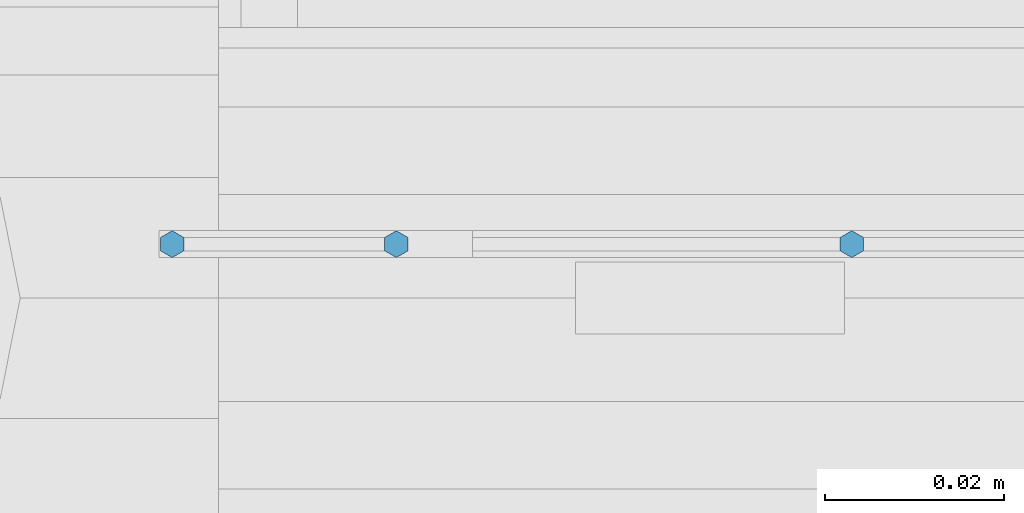
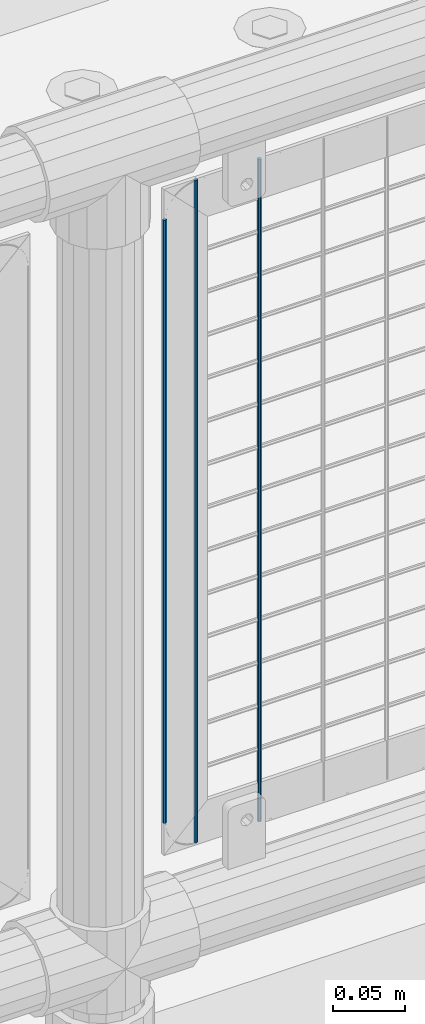
# One storey, part 103 of 242: 3 columns.
"""IFC2X3 building model written with IfcOpenShell, lengths in millimetres."""

from ifc_helpers import new_model, si_unit, frame, origin_with_axes, place, context, subcontext, project, spatial, faceted_brep, material, type_object, element, save


model = new_model("IFC2X3")

# Units and contexts
model_context = context("Model", 3, precision=1e-05, world=origin_with_axes())
body_context = subcontext(model_context, "Body", "Model", "MODEL_VIEW")
ifc_project = project(units=[si_unit("LENGTHUNIT", "METRE", prefix="MILLI"), si_unit("AREAUNIT", "SQUARE_METRE"), si_unit("VOLUMEUNIT", "CUBIC_METRE"), si_unit("MASSUNIT", "GRAM", prefix="KILO"), si_unit("TIMEUNIT", "SECOND"), si_unit("PLANEANGLEUNIT", "RADIAN"), si_unit("SOLIDANGLEUNIT", "STERADIAN"), si_unit("THERMODYNAMICTEMPERATUREUNIT", "DEGREE_CELSIUS"), si_unit("LUMINOUSINTENSITYUNIT", "LUMEN")], contexts=[model_context])

# Site, building, storey
site_placement = place(None, origin_with_axes())
site = spatial("IfcSite", under=ifc_project, at=site_placement, CompositionType="ELEMENT")
building_placement = place(site_placement, origin_with_axes())
building = spatial("IfcBuilding", under=site, at=building_placement, Name="Standard", CompositionType="ELEMENT")
storey_placement = place(building_placement, origin_with_axes())
storey = spatial("IfcBuildingStorey", under=building, at=storey_placement, Name="Undefined", CompositionType="ELEMENT", Elevation=0.0)

# Columns
ifc_material = material(Name="Misc_Undefined")
column_type = type_object("IfcColumnType", Name="D3", PredefinedType="NOTDEFINED")
column_1_placement = place(storey_placement, frame((-25368.207, -19329.5, 353.02), z_axis=(-1.0, 0.0, 0.0), x_axis=(0.0, 0.0, 1.0)))
element("IfcColumn", 1, at=column_1_placement, inside=storey, type_object=column_type, material=ifc_material, ObjectType="D3", context=body_context, shape_type="Brep", body=[
    faceted_brep([(0.0, -1.50000000000364, 0.0), (-3.63797880709171e-12, -0.750000000003638, -1.29903810567669), (560.0, -0.75, -1.29903810567703), (560.0, -1.5, 0.0), (0.0, 0.749999999996362, -1.29903810567669), (560.0, 0.75, -1.29903810567703), (-3.63797880709171e-12, 1.49999999999636, 0.0), (560.0, 1.5, 0.0), (0.0, 0.749999999996362, 1.29903810567669), (560.0, 0.75, 1.29903810567703), (-3.63797880709171e-12, -0.750000000003638, 1.29903810567669), (560.0, -0.75, 1.29903810567703)], [[[0, 1, 2, 3]], [[1, 4, 5, 2]], [[4, 6, 7, 5]], [[6, 8, 9, 7]], [[8, 10, 11, 9]], [[10, 0, 3, 11]], [[5, 7, 9, 11, 3, 2]], [[10, 8, 6, 4, 1, 0]]]),
])
column_2_placement = place(storey_placement, frame((-25444.0, -19329.5, 378.02), z_axis=(-1.0, 0.0, 0.0), x_axis=(0.0, 0.0, 1.0)))
element("IfcColumn", 2, at=column_2_placement, inside=storey, type_object=column_type, material=ifc_material, ObjectType="D3", context=body_context, shape_type="Brep", body=[
    faceted_brep([(0.0, -1.50000000000364, 0.0), (-3.63797880709171e-12, -0.750000000003638, -1.29903810567669), (510.0, -0.75, -1.29903810567703), (510.0, -1.5, 0.0), (0.0, 0.749999999996362, -1.29903810567669), (510.0, 0.75, -1.29903810567703), (-3.63797880709171e-12, 1.49999999999636, 0.0), (510.0, 1.5, 0.0), (0.0, 0.749999999996362, 1.29903810567669), (510.0, 0.75, 1.29903810567703), (-3.63797880709171e-12, -0.750000000003638, 1.29903810567669), (510.0, -0.75, 1.29903810567703)], [[[0, 1, 2, 3]], [[1, 4, 5, 2]], [[4, 6, 7, 5]], [[6, 8, 9, 7]], [[8, 10, 11, 9]], [[10, 0, 3, 11]], [[5, 7, 9, 11, 3, 2]], [[10, 8, 6, 4, 1, 0]]]),
])
column_3_placement = place(storey_placement, frame((-25419.0, -19329.5, 353.02), z_axis=(-1.0, 0.0, 0.0), x_axis=(0.0, 0.0, 1.0)))
element("IfcColumn", 3, at=column_3_placement, inside=storey, type_object=column_type, material=ifc_material, ObjectType="D3", context=body_context, shape_type="Brep", body=[
    faceted_brep([(0.0, -1.50000000000364, 0.0), (-3.63797880709171e-12, -0.750000000003638, -1.29903810567669), (560.0, -0.75, -1.29903810567703), (560.0, -1.5, 0.0), (0.0, 0.749999999996362, -1.29903810567669), (560.0, 0.75, -1.29903810567703), (-3.63797880709171e-12, 1.49999999999636, 0.0), (560.0, 1.5, 0.0), (0.0, 0.749999999996362, 1.29903810567669), (560.0, 0.75, 1.29903810567703), (-3.63797880709171e-12, -0.750000000003638, 1.29903810567669), (560.0, -0.75, 1.29903810567703)], [[[0, 1, 2, 3]], [[1, 4, 5, 2]], [[4, 6, 7, 5]], [[6, 8, 9, 7]], [[8, 10, 11, 9]], [[10, 0, 3, 11]], [[5, 7, 9, 11, 3, 2]], [[10, 8, 6, 4, 1, 0]]]),
])

save(model, "model.ifc")
